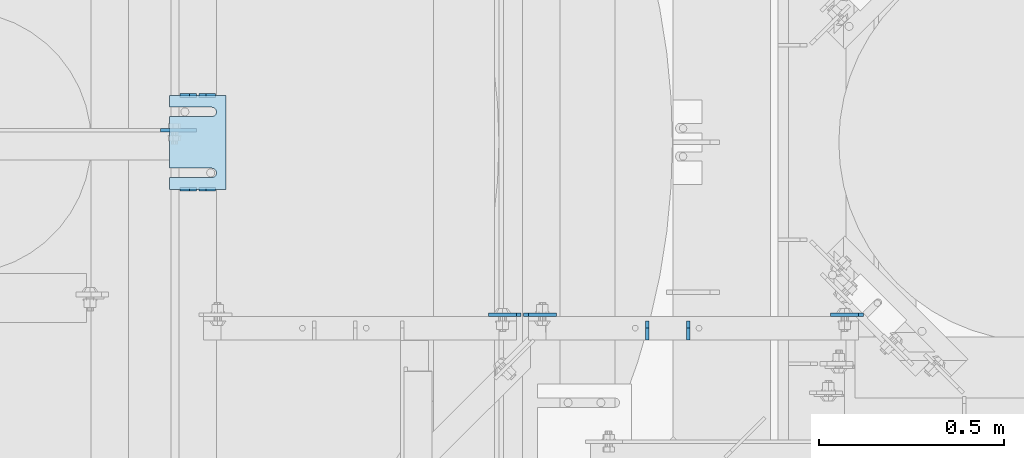
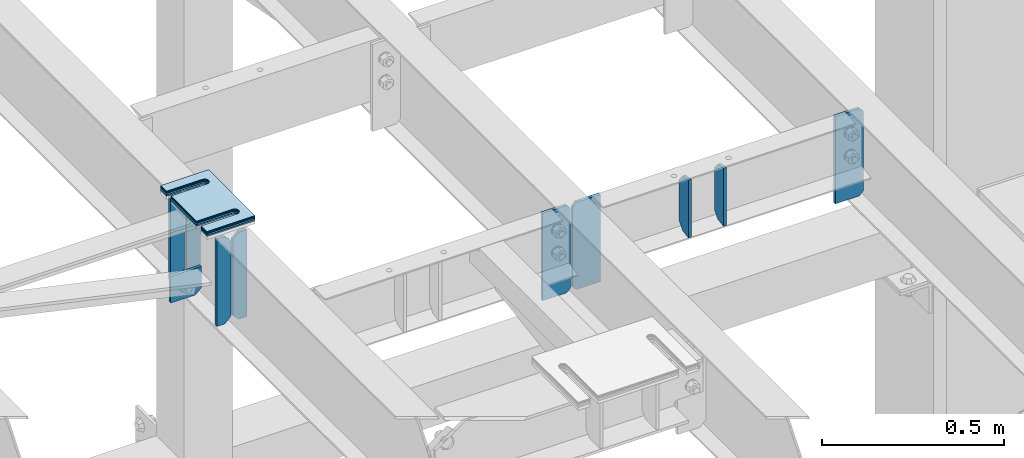
# One storey, part 1787 of 1876: 15 plates, 9 elements without a shape of their own.
"""IFC2X3 building model written with IfcOpenShell, lengths in millimetres."""

import ifcopenshell
import ifcopenshell.guid

model = None  # the IFC model being written
_history = None  # IfcOwnerHistory: only IFC2X3 demands one
_inside = {}  # id of a spatial element -> (the spatial element, [elements in it])
_under = {}  # id of a project, library or spatial element -> (it, [spatial elements below it])
_declared = {}  # id of a project -> (the project, [libraries it declares])
_typed = {}  # id of a type object -> (the type object, [elements of that type])
_made_of = {}  # id of a material, layer set ... -> (it, [elements and type objects made of it])


def new_model(schema):
    """Start an empty IFC model of exactly this schema.

    Asked for "IFC4X3", IfcOpenShell would pick the latest addendum, in which some entities
    have other attributes; the version numbers below select the first issue.
    IFC2X3 requires an IfcOwnerHistory on every rooted entity: one is made here for all.
    """
    global model, _history
    if schema == "IFC4X3":
        model = ifcopenshell.file(schema_version=(4, 3, 0, 0))
    else:
        model = ifcopenshell.file(schema=schema)
    _inside.clear()
    _under.clear()
    _declared.clear()
    _typed.clear()
    _made_of.clear()
    _history = None
    if model.schema == "IFC2X3":
        org = make("IfcOrganization", Name="unknown")
        user = make(
            "IfcPersonAndOrganization",
            ThePerson=make("IfcPerson", FamilyName="unknown"),
            TheOrganization=org,
        )
        app = make(
            "IfcApplication",
            ApplicationDeveloper=org,
            Version="unknown",
            ApplicationFullName="unknown",
            ApplicationIdentifier="unknown",
        )
        _history = make(
            "IfcOwnerHistory",
            OwningUser=user,
            OwningApplication=app,
            ChangeAction="ADDED",
            CreationDate=0,
        )
    return model


def make(cls, **values):
    """One entity of the class cls with the attributes given. An attribute that is None is left unset."""
    return model.create_entity(
        cls, **{name: value for name, value in values.items() if value is not None}
    )


def rooted(cls, **values):
    """An entity with a GlobalId (a new one), such as an element, a storey or a relation."""
    return make(cls, GlobalId=ifcopenshell.guid.new(), OwnerHistory=_history, **values)


def si_unit(unit_type, name, prefix=None):
    """IfcSIUnit, for example si_unit("LENGTHUNIT", "METRE", prefix="MILLI")."""
    return make("IfcSIUnit", UnitType=unit_type, Prefix=prefix, Name=name)


def assignment(units):
    """IfcUnitAssignment: the units of a project."""
    return None if units is None else make("IfcUnitAssignment", Units=units)


def point(xyz):
    """IfcCartesianPoint."""
    return None if xyz is None else make("IfcCartesianPoint", Coordinates=xyz)


def direction(xyz):
    """IfcDirection."""
    return None if xyz is None else make("IfcDirection", DirectionRatios=xyz)


def frame(location, z_axis=None, x_axis=None):
    """IfcAxis2Placement3D, a coordinate frame: its origin and axes. An axis left out is left unset."""
    return make(
        "IfcAxis2Placement3D",
        Location=point(location),
        Axis=direction(z_axis),
        RefDirection=direction(x_axis),
    )


def origin_with_axes():
    """The frame at (0, 0, 0) with the z axis (0, 0, 1) and the x axis (1, 0, 0) written out."""
    return frame((0.0, 0.0, 0.0), z_axis=(0.0, 0.0, 1.0), x_axis=(1.0, 0.0, 0.0))


def place(relative_to, where):
    """IfcLocalPlacement: puts the frame where relative to a parent placement (None: the world)."""
    return make(
        "IfcLocalPlacement", PlacementRelTo=relative_to, RelativePlacement=where
    )


def context(
    kind, dimensions, precision=None, world=None, true_north=None, identifier=None
):
    """IfcGeometricRepresentationContext, for example the 3D "Model" context."""
    return make(
        "IfcGeometricRepresentationContext",
        ContextIdentifier=identifier,
        ContextType=kind,
        CoordinateSpaceDimension=dimensions,
        Precision=precision,
        WorldCoordinateSystem=world,
        TrueNorth=true_north,
    )


def subcontext(parent, identifier, kind, view, scale=None):
    """IfcGeometricRepresentationSubContext, for example "Body" below "Model"."""
    return make(
        "IfcGeometricRepresentationSubContext",
        ContextIdentifier=identifier,
        ContextType=kind,
        ParentContext=parent,
        TargetScale=scale,
        TargetView=view,
    )


def project(units=None, contexts=None):
    """IfcProject with its units and contexts."""
    return rooted(
        "IfcProject",
        Name="project",
        RepresentationContexts=contexts,
        UnitsInContext=assignment(units),
    )


def spatial(cls, under=None, at=None, **own):
    """A site, building, storey or space (cls), placed at a placement, below another one or the project."""
    s = rooted(cls, ObjectPlacement=at, **own)
    if under is not None:
        _under.setdefault(under.id(), (under, []))[1].append(s)
    return s


def faces_of(points, faces, orient=None, outer=None):
    """IfcFace entities. A face is a list of loops; a loop is a list of indices into points, from 0.

    orient and outer hold one flag for each loop. By default every Orientation is true, the
    first loop of a face is its IfcFaceOuterBound and the others are IfcFaceBound.
    """
    made = []
    for i, loops in enumerate(faces):
        bounds = []
        for j, loop in enumerate(loops):
            is_outer = j == 0 if outer is None else outer[i][j]
            bounds.append(
                make(
                    "IfcFaceOuterBound" if is_outer else "IfcFaceBound",
                    Bound=make("IfcPolyLoop", Polygon=[points[k] for k in loop]),
                    Orientation=True if orient is None else orient[i][j],
                )
            )
        made.append(make("IfcFace", Bounds=bounds))
    return made


def faceted_brep(points, faces, orient=None, outer=None, voids=None):
    """IfcFacetedBrep: a solid bounded by flat faces; with voids (closed shells), ...WithVoids."""
    shared = [point(p) for p in points]
    hull = make("IfcClosedShell", CfsFaces=faces_of(shared, faces, orient, outer))
    if voids is None:
        return make("IfcFacetedBrep", Outer=hull)
    return make(
        "IfcFacetedBrepWithVoids",
        Outer=hull,
        Voids=[
            make(cls, CfsFaces=faces_of(shared, fs, o, b)) for cls, fs, o, b in voids
        ],
    )


def shape(context_of_items, identifier, shape_type, items):
    """IfcShapeRepresentation: the items that make up one representation, for example the "Body"."""
    return make(
        "IfcShapeRepresentation",
        ContextOfItems=context_of_items,
        RepresentationIdentifier=identifier,
        RepresentationType=shape_type,
        Items=items,
    )


def material(Name=None, Category=None):
    """IfcMaterial."""
    return make("IfcMaterial", Name=Name, Category=Category)


def made_of(thing, what):
    """Note that an element or type object is made of a material, layer set ...; save() writes the relation."""
    if what is not None:
        _made_of.setdefault(what.id(), (what, []))[1].append(thing)
    return thing


def type_object(cls, material=None, **own):
    """A type object (cls), such as IfcWallType, which elements share."""
    return made_of(rooted(cls, **own), material)


def element(
    cls,
    number,
    at=None,
    inside=None,
    cuts=None,
    type_object=None,
    material=None,
    context=None,
    identifier="Body",
    shape_type=None,
    held_by="IfcProductDefinitionShape",
    body=None,
    shapes=None,
    **own,
):
    """One element of the class cls, such as IfcWall. Its Tag is "e" and its number.

    at: its placement. inside: the storey or other place that contains it. cuts: it is an
    opening in that element (IfcRelVoidsElement). A single representation is given by context,
    identifier, shape_type and body (its items); several are given by shapes. held_by: the class
    of the entity that holds the representations. save() writes the other relations.
    """
    e = rooted(cls, Tag="e%d" % number, ObjectPlacement=at, **own)
    if body is not None:
        shapes = [shape(context, identifier, shape_type, body)]
    if shapes is not None:
        e.Representation = make(held_by, Representations=shapes)
    if inside is not None:
        _inside.setdefault(inside.id(), (inside, []))[1].append(e)
    if cuts is not None:
        rooted(
            "IfcRelVoidsElement", RelatingBuildingElement=cuts, RelatedOpeningElement=e
        )
    if type_object is not None:
        _typed.setdefault(type_object.id(), (type_object, []))[1].append(e)
    return made_of(e, material)


def aggregate(whole, parts):
    """IfcRelAggregates: a whole, such as a stair, and the parts it consists of."""
    return rooted("IfcRelAggregates", RelatingObject=whole, RelatedObjects=parts)


def save(model, path):
    """Write the relations noted so far, then the file.

    IfcRelAggregates (storeys below a building ...), IfcRelContainedInSpatialStructure (elements
    in a storey), IfcRelDefinesByType, IfcRelAssociatesMaterial and IfcRelDeclares: one each for
    every whole, place, type object, material and project.
    """
    for whole, parts in _under.values():
        aggregate(whole, parts)
    for where, things in _inside.values():
        rooted(
            "IfcRelContainedInSpatialStructure",
            RelatedElements=things,
            RelatingStructure=where,
        )
    for kind, things in _typed.values():
        rooted("IfcRelDefinesByType", RelatedObjects=things, RelatingType=kind)
    for what, things in _made_of.values():
        rooted("IfcRelAssociatesMaterial", RelatedObjects=things, RelatingMaterial=what)
    for by, libraries in _declared.values():
        rooted("IfcRelDeclares", RelatingContext=by, RelatedDefinitions=libraries)
    model.write(path)


model = new_model("IFC2X3")

# Units and contexts
model_context = context("Model", 3, precision=1e-05, world=origin_with_axes())
body_context = subcontext(model_context, "Body", "Model", "MODEL_VIEW")
ifc_project = project(units=[si_unit("LENGTHUNIT", "METRE", prefix="MILLI"), si_unit("AREAUNIT", "SQUARE_METRE"), si_unit("VOLUMEUNIT", "CUBIC_METRE"), si_unit("MASSUNIT", "GRAM", prefix="KILO"), si_unit("TIMEUNIT", "SECOND"), si_unit("PLANEANGLEUNIT", "RADIAN"), si_unit("SOLIDANGLEUNIT", "STERADIAN"), si_unit("THERMODYNAMICTEMPERATUREUNIT", "DEGREE_CELSIUS"), si_unit("LUMINOUSINTENSITYUNIT", "LUMEN")], contexts=[model_context])

# Site, building, storey
site_placement = place(None, origin_with_axes())
site = spatial("IfcSite", under=ifc_project, at=site_placement, CompositionType="ELEMENT")
building_placement = place(site_placement, origin_with_axes())
building = spatial("IfcBuilding", under=site, at=building_placement, Name="Undefined", CompositionType="ELEMENT")
storey_placement = place(building_placement, origin_with_axes())
storey = spatial("IfcBuildingStorey", under=building, at=storey_placement, Name="Undefined", CompositionType="ELEMENT", Elevation=0.0)

# Assembly, plates
assembly_1_placement = place(storey_placement, origin_with_axes())
assembly_1 = element("IfcElementAssembly", 1, at=assembly_1_placement, inside=storey, Name="BEAM", AssemblyPlace="NOTDEFINED", PredefinedType="RIGID_FRAME")
ifc_material = material(Name="STEEL/A36")
plate_type_1 = type_object("IfcPlateType", PredefinedType="NOTDEFINED")
plate_1_placement = place(assembly_1_placement, frame((3879.85, 11353.8028363018, 17684.75), z_axis=(0.0, 0.0, 1.0), x_axis=(-1.0, 0.0, 0.0)))
plate_1 = element("IfcPlate", 2, at=plate_1_placement, type_object=plate_type_1, material=ifc_material, Name="PLATE", context=body_context, shape_type="Brep", body=[
    faceted_brep([(0.0, -4.76249999999982, 0.0), (0.0, -4.76249999999982, 292.100006103516), (0.0, 4.76249999999982, 292.100006103516), (0.0, 4.76249999999982, 0.0), (25.4000015258789, -4.76250000000073, 292.100006103516), (25.4000015258789, 4.76250000000073, 292.100006103516), (44.4500007629395, -4.76250000000073, 273.050006866455), (44.4500007629395, 4.76250000000073, 273.050006866455), (44.4500007629395, -4.76250000000073, 19.0499992370605), (44.4500007629395, 4.76250000000073, 19.0499992370605), (25.4000015258789, -4.76250000000073, 0.0), (25.4000015258789, 4.76250000000073, 0.0)], [[[0, 1, 2, 3]], [[1, 4, 5, 2]], [[4, 6, 7, 5]], [[6, 8, 9, 7]], [[8, 10, 11, 9]], [[10, 0, 3, 11]], [[5, 7, 9, 11, 3, 2]], [[10, 8, 6, 4, 1, 0]]]),
])
plate_2_placement = place(assembly_1_placement, frame((3829.05, 11353.8028363018, 17684.75), z_axis=(0.0, 0.0, 1.0), x_axis=(-1.0, 0.0, 0.0)))
plate_2 = element("IfcPlate", 3, at=plate_2_placement, type_object=plate_type_1, material=ifc_material, Name="PLATE", context=body_context, shape_type="Brep", body=[
    faceted_brep([(0.0, -4.76249999999982, 19.0499992370605), (0.0, -4.76249999999982, 273.050006866455), (0.0, 4.76249999999982, 273.050006866455), (0.0, 4.76249999999982, 19.0499992370605), (19.0499992370605, -4.76249999999982, 292.100006103516), (19.0499992370605, 4.76249999999982, 292.100006103516), (44.4500007629395, -4.76250000000073, 292.100006103516), (44.4500007629395, 4.76250000000073, 292.100006103516), (44.4500007629395, -4.76249999999982, 0.0), (44.4500007629395, 4.76249999999982, 0.0), (19.0499992370605, -4.76249999999982, 0.0), (19.0499992370605, 4.76249999999982, 0.0)], [[[0, 1, 2, 3]], [[1, 4, 5, 2]], [[4, 6, 7, 5]], [[6, 8, 9, 7]], [[8, 10, 11, 9]], [[10, 0, 3, 11]], [[5, 7, 9, 11, 3, 2]], [[10, 8, 6, 4, 1, 0]]]),
])
plate_3_placement = place(assembly_1_placement, frame((3879.85, 11607.8023762535, 17684.75), z_axis=(0.0, 0.0, 1.0), x_axis=(-1.0, 0.0, 0.0)))
plate_3 = element("IfcPlate", 4, at=plate_3_placement, type_object=plate_type_1, material=ifc_material, Name="PLATE", context=body_context, shape_type="Brep", body=[
    faceted_brep([(0.0, -4.76249999999982, 0.0), (0.0, -4.76249999999982, 292.100006103516), (0.0, 4.76249999999982, 292.100006103516), (0.0, 4.76249999999982, 0.0), (25.4000015258789, -4.76250000000073, 292.100006103516), (25.4000015258789, 4.76250000000073, 292.100006103516), (44.4500007629395, -4.76250000000073, 273.050006866455), (44.4500007629395, 4.76250000000073, 273.050006866455), (44.4500007629395, -4.76250000000073, 19.0499992370605), (44.4500007629395, 4.76250000000073, 19.0499992370605), (25.4000015258789, -4.76250000000073, 0.0), (25.4000015258789, 4.76250000000073, 0.0)], [[[0, 1, 2, 3]], [[1, 4, 5, 2]], [[4, 6, 7, 5]], [[6, 8, 9, 7]], [[8, 10, 11, 9]], [[10, 0, 3, 11]], [[5, 7, 9, 11, 3, 2]], [[10, 8, 6, 4, 1, 0]]]),
])
plate_4_placement = place(assembly_1_placement, frame((3829.05, 11607.8023762535, 17684.75), z_axis=(0.0, 0.0, 1.0), x_axis=(-1.0, 0.0, 0.0)))
plate_4 = element("IfcPlate", 5, at=plate_4_placement, type_object=plate_type_1, material=ifc_material, Name="PLATE", context=body_context, shape_type="Brep", body=[
    faceted_brep([(0.0, -4.76249999999982, 19.0499992370605), (0.0, -4.76249999999982, 273.050006866455), (0.0, 4.76249999999982, 273.050006866455), (0.0, 4.76249999999982, 19.0499992370605), (19.0499992370605, -4.76249999999982, 292.100006103516), (19.0499992370605, 4.76249999999982, 292.100006103516), (44.4500007629395, -4.76250000000073, 292.100006103516), (44.4500007629395, 4.76250000000073, 292.100006103516), (44.4500007629395, -4.76249999999982, 0.0), (44.4500007629395, 4.76249999999982, 0.0), (19.0499992370605, -4.76249999999982, 0.0), (19.0499992370605, 4.76249999999982, 0.0)], [[[0, 1, 2, 3]], [[1, 4, 5, 2]], [[4, 6, 7, 5]], [[6, 8, 9, 7]], [[8, 10, 11, 9]], [[10, 0, 3, 11]], [[5, 7, 9, 11, 3, 2]], [[10, 8, 6, 4, 1, 0]]]),
])
plate_type_2 = type_object("IfcPlateType", PredefinedType="NOTDEFINED")
plate_5_placement = place(assembly_1_placement, frame((3731.43869979147, 11514.1401187102, 17773.7575293383), z_axis=(1.0, 0.0, 0.0), x_axis=(0.0, 0.0, -1.0)))
plate_5 = element("IfcPlate", 6, at=plate_5_placement, type_object=plate_type_2, material=ifc_material, Name="PLATE", context=body_context, shape_type="Brep", body=[
    faceted_brep([(0.0, -4.76249999999982, 0.0), (0.0, -4.76249999991705, 97.6116790771484), (0.0, 4.76250000008258, 97.6116790771498), (0.0, 4.76249999999982, 0.0), (69.9575309753418, -4.76249999991705, 97.6116790771484), (69.9575309753418, 4.76250000008258, 97.6116790771498), (89.0075302124023, -4.76249999993524, 78.5616798400883), (89.0075302124023, 4.76250000006621, 78.5616798400893), (89.0075302124023, -4.76249999999891, 1.81898940354586e-12), (89.0075302124023, 4.76250000000255, 3.18323145620525e-12)], [[[0, 1, 2, 3]], [[1, 4, 5, 2]], [[4, 6, 7, 5]], [[6, 8, 9, 7]], [[8, 0, 3, 9]], [[5, 7, 9, 3, 2]], [[8, 6, 4, 1, 0]]]),
])
aggregate(assembly_1, [plate_1, plate_2, plate_3, plate_4, plate_5])

# Assembly, plate
assembly_2_placement = place(storey_placement, origin_with_axes())
assembly_2 = element("IfcElementAssembly", 7, at=assembly_2_placement, inside=storey, Name="BEAM", AssemblyPlace="NOTDEFINED", PredefinedType="RIGID_FRAME")
plate_6_placement = place(assembly_2_placement, frame((5635.625, 11014.0759998322, 17684.75), z_axis=(0.0, 0.0, 1.0), x_axis=(-1.0, 0.0, 0.0)))
plate_6 = element("IfcPlate", 8, at=plate_6_placement, type_object=plate_type_2, material=ifc_material, Name="PLATE", context=body_context, shape_type="Brep", body=[
    faceted_brep([(3.7040990719106e-08, -4.76249999999982, 12.6999998092651), (0.0, -4.76249999999982, 279.40000629425), (0.0, 4.76249999999982, 279.40000629425), (3.70396264770534e-08, 4.76249999999982, 12.6999998092651), (12.6999998092651, -4.76249999999982, 292.100006103516), (12.6999998092651, 4.76249999999982, 292.100006103516), (88.9000015258789, -4.76249999999982, 292.100006103516), (88.9000015258789, 4.76249999999982, 292.100006103516), (88.9000015258789, -4.76249999999982, 0.0), (88.9000015258789, 4.76249999999982, 0.0), (12.699999809267, -4.76249999999754, 1.09139364212751e-11), (12.6999998092651, 4.76250000000255, 1.09139364212751e-11)], [[[0, 1, 2, 3]], [[1, 4, 5, 2]], [[4, 6, 7, 5]], [[6, 8, 9, 7]], [[8, 10, 11, 9]], [[10, 0, 3, 11]], [[5, 7, 9, 11, 3, 2]], [[10, 8, 6, 4, 1, 0]]]),
])
aggregate(assembly_2, [plate_6])

# Assembly, plates
assembly_3_placement = place(storey_placement, origin_with_axes())
assembly_3 = element("IfcElementAssembly", 9, at=assembly_3_placement, inside=storey, Name="BEAM", AssemblyPlace="NOTDEFINED", PredefinedType="RIGID_FRAME")
plate_7_placement = place(assembly_3_placement, frame((4714.875, 11014.0759998322, 17684.75), z_axis=(0.0, 0.0, 1.0), x_axis=(1.0, 0.0, 0.0)))
plate_7 = element("IfcPlate", 10, at=plate_7_placement, type_object=plate_type_2, material=ifc_material, Name="PLATE", context=body_context, shape_type="Brep", body=[
    faceted_brep([(3.7040990719106e-08, -4.76249999999982, 12.6999998092651), (0.0, -4.76249999999982, 279.40000629425), (0.0, 4.76249999999982, 279.40000629425), (3.70396264770534e-08, 4.76249999999982, 12.6999998092651), (12.6999998092651, -4.76249999999982, 292.100006103516), (12.6999998092651, 4.76249999999982, 292.100006103516), (88.9000015258789, -4.76249999999982, 292.100006103516), (88.9000015258789, 4.76249999999982, 292.100006103516), (88.9000015258789, -4.76249999999982, 0.0), (88.9000015258789, 4.76249999999982, 0.0), (12.699999809267, -4.76249999999754, 1.09139364212751e-11), (12.6999998092651, 4.76250000000255, 1.09139364212751e-11)], [[[0, 1, 2, 3]], [[1, 4, 5, 2]], [[4, 6, 7, 5]], [[6, 8, 9, 7]], [[8, 10, 11, 9]], [[10, 0, 3, 11]], [[5, 7, 9, 11, 3, 2]], [[10, 8, 6, 4, 1, 0]]]),
])
plate_8_placement = place(assembly_3_placement, frame((4708.525, 11014.0754999161, 17684.75), z_axis=(0.0, 0.0, 1.0), x_axis=(-1.0, 0.0, 0.0)))
plate_8 = element("IfcPlate", 11, at=plate_8_placement, type_object=plate_type_2, material=ifc_material, Name="PLATE", context=body_context, shape_type="Brep", body=[
    faceted_brep([(3.7040990719106e-08, -4.76249999999982, 12.6999998092651), (0.0, -4.76249999999982, 279.40000629425), (0.0, 4.76249999999982, 279.40000629425), (3.70396264770534e-08, 4.76249999999982, 12.6999998092651), (12.6999998092651, -4.76249999999982, 292.100006103516), (12.6999998092651, 4.76249999999982, 292.100006103516), (88.9000015258789, -4.76249999999982, 292.100006103516), (88.9000015258789, 4.76249999999982, 292.100006103516), (88.9000015258789, -4.76249999999982, 0.0), (88.9000015258789, 4.76249999999982, 0.0), (12.699999809267, -4.76249999999754, 1.09139364212751e-11), (12.6999998092651, 4.76250000000255, 1.09139364212751e-11)], [[[0, 1, 2, 3]], [[1, 4, 5, 2]], [[4, 6, 7, 5]], [[6, 8, 9, 7]], [[8, 10, 11, 9]], [[10, 0, 3, 11]], [[5, 7, 9, 11, 3, 2]], [[10, 8, 6, 4, 1, 0]]]),
])
aggregate(assembly_3, [plate_7, plate_8])

# Assembly, plate
assembly_4_placement = place(storey_placement, origin_with_axes())
assembly_4 = element("IfcElementAssembly", 12, at=assembly_4_placement, inside=storey, Name="SHIM PLATE", AssemblyPlace="NOTDEFINED", PredefinedType="RIGID_FRAME")
plate_type_3 = type_object("IfcPlateType", PredefinedType="NOTDEFINED")
plate_9_placement = place(assembly_4_placement, frame((3908.44515556677, 11353.8028259284, 18009.3925), z_axis=(-1.0, 0.0, 0.0), x_axis=(0.0, 1.0, 0.0)))
plate_9 = element("IfcPlate", 13, at=plate_9_placement, type_object=plate_type_3, material=ifc_material, Name="SHIM PLATE", context=body_context, shape_type="Brep", body=[
    faceted_brep([(31.7473236467022, -0.793499999999767, 152.398895263674), (31.7495452849444, -0.793499999999767, 38.0994505459066), (31.7495452849444, 0.793499999999767, 38.0994505459066), (31.7473236467022, 0.793499999999767, 152.398895263674), (33.4510181364694, -0.793499999999767, 31.7494480392982), (33.4510181364694, 0.793499999999767, 31.7494480392982), (38.0995388011806, -0.793499999999767, 27.1009216783834), (38.0995388011806, 0.793499999999767, 27.1009216783834), (44.4495392228328, -0.793499999999767, 25.3994410457015), (44.4495392228328, 0.793499999999767, 25.3994410457015), (50.7995409628356, -0.793499999999767, 27.1009167582527), (50.7995409628356, 0.793499999999767, 27.1009167582527), (55.4480652293469, -0.793499999999767, 31.7494395173824), (55.4480652293469, 0.793499999999767, 31.7494395173824), (57.14954300102, -0.793499999999767, 38.0994407056476), (57.14954300102, 0.793499999999767, 38.0994407056476), (57.1473213626687, -0.793499999999767, 152.398894419415), (57.1473213626687, 0.793499999999767, 152.398895263676), (9.09494701772928e-13, -0.793499999999767, 0.0), (1.98268335225293e-05, -0.793499999999767, 152.398895263672), (1.98268335225293e-05, 0.793499999999767, 152.398895263672), (9.09494701772928e-13, 0.793499999999767, 0.0), (253.999542236328, -0.793499999999767, 6.16182660451159e-11), (253.999542236328, 0.793499999999767, 6.16182660451159e-11), (253.999557495107, -0.793499999999767, 152.398895263688), (253.999557495107, 0.793499999999767, 152.398895263688), (222.247321362667, 0.793499999999767, 152.398895263686), (222.247321362667, -0.793499999999767, 152.398895410166), (222.249543001019, 0.793499999999767, 38.0994416963979), (222.249543001019, -0.793499999999767, 38.0994416963979), (220.548065229345, 0.793499999999767, 31.7494405081325), (220.548065229345, -0.793499999999767, 31.7494405081325), (215.899540962834, 0.793499999999767, 27.100917749003), (215.899540962834, -0.793499999999767, 27.100917749003), (209.549539222831, 0.793499999999767, 25.3994420364518), (209.549539222831, -0.793499999999767, 25.3994420364518), (203.199538801179, 0.793499999999767, 27.1009226691335), (203.199538801179, -0.793499999999767, 27.1009226691335), (198.551018136468, 0.793499999999767, 31.7494490300483), (198.551018136468, -0.793499999999767, 31.7494490300483), (196.849545284943, 0.793499999999767, 38.0994515366567), (196.849545284943, -0.793499999999767, 38.0994515366567), (196.847323646701, -0.793499999999767, 152.398895263684), (196.847323646701, 0.793499999999767, 152.398895263684)], [[[0, 1, 2, 3]], [[4, 5, 2, 1]], [[6, 7, 5, 4]], [[8, 9, 7, 6]], [[10, 11, 9, 8]], [[12, 13, 11, 10]], [[14, 15, 13, 12]], [[16, 17, 15, 14]], [[18, 19, 20, 21]], [[22, 18, 21, 23]], [[24, 22, 23, 25]], [[24, 25, 26, 27]], [[27, 26, 28, 29]], [[29, 28, 30, 31]], [[31, 30, 32, 33]], [[33, 32, 34, 35]], [[35, 34, 36, 37]], [[37, 36, 38, 39]], [[39, 38, 40, 41]], [[42, 41, 40, 43]], [[12, 10, 8, 6, 4, 1, 0, 19, 18, 22, 24, 27, 29, 31, 33, 35, 37, 39, 41, 42, 16, 14]], [[20, 19, 0, 3]], [[43, 40, 38, 36, 34, 32, 30, 28, 26, 25, 23, 21, 20, 3, 2, 5, 7, 9, 11, 13, 15, 17]], [[42, 43, 17, 16]]]),
])
aggregate(assembly_4, [plate_9])

assembly_5_placement = place(storey_placement, origin_with_axes())
assembly_5 = element("IfcElementAssembly", 14, at=assembly_5_placement, inside=storey, Name="SHIM PLATE", AssemblyPlace="NOTDEFINED", PredefinedType="RIGID_FRAME")
plate_type_4 = type_object("IfcPlateType", PredefinedType="NOTDEFINED")
plate_10_placement = place(assembly_5_placement, frame((3908.4451555663, 11353.8028259282, 18007.0115), z_axis=(-1.0, 0.0, 0.0), x_axis=(0.0, 1.0, 0.0)))
plate_10 = element("IfcPlate", 15, at=plate_10_placement, type_object=plate_type_4, material=ifc_material, Name="SHIM PLATE", context=body_context, shape_type="Brep", body=[
    faceted_brep([(31.7473236467022, -1.58750000000146, 152.398895263674), (31.7495452849444, -1.58750000000146, 38.0994505459066), (31.7495452849444, 1.58750000000146, 38.0994505459066), (31.7473236467022, 1.58750000000146, 152.398895263674), (33.4510181364694, -1.58750000000146, 31.7494480392982), (33.4510181364694, 1.58750000000146, 31.7494480392982), (38.0995388011806, -1.58750000000146, 27.1009216783834), (38.0995388011806, 1.58750000000146, 27.1009216783834), (44.4495392228328, -1.58750000000146, 25.3994410457015), (44.4495392228328, 1.58750000000146, 25.3994410457015), (50.7995409628356, -1.58750000000146, 27.1009167582527), (50.7995409628356, 1.58750000000146, 27.1009167582527), (55.4480652293469, -1.58750000000146, 31.7494395173824), (55.4480652293469, 1.58750000000146, 31.7494395173824), (57.14954300102, -1.58750000000146, 38.0994407056476), (57.14954300102, 1.58750000000146, 38.0994407056476), (57.1473213626687, -1.58750000000146, 152.398894419415), (57.1473213626687, 1.58750000000146, 152.398895263676), (9.09494701772928e-13, -1.58750000000146, 4.54747350886464e-13), (1.98264133359771e-05, -1.58750000000146, 152.398895263672), (1.98264133359771e-05, 1.58750000000146, 152.398895263672), (9.09494701772928e-13, 1.58750000000146, 4.54747350886464e-13), (253.999542236328, -1.58750000000146, 6.16182660451159e-11), (253.999542236328, 1.58750000000146, 6.16182660451159e-11), (253.999557495107, -1.58750000000146, 152.398895263688), (253.999557495107, 1.58750000000146, 152.398895263688), (222.247321362667, 1.58750000000146, 152.398895263686), (222.247321362667, -1.58750000000146, 152.398895410166), (222.249543001019, 1.58750000000146, 38.0994416963979), (222.249543001019, -1.58750000000146, 38.0994416963979), (220.548065229345, 1.58750000000146, 31.7494405081325), (220.548065229345, -1.58750000000146, 31.7494405081325), (215.899540962834, 1.58750000000146, 27.100917749003), (215.899540962834, -1.58750000000146, 27.100917749003), (209.549539222831, 1.58750000000146, 25.3994420364518), (209.549539222831, -1.58750000000146, 25.3994420364518), (203.199538801179, 1.58750000000146, 27.1009226691335), (203.199538801179, -1.58750000000146, 27.1009226691335), (198.551018136468, 1.58750000000146, 31.7494490300483), (198.551018136468, -1.58750000000146, 31.7494490300483), (196.849545284943, 1.58750000000146, 38.0994515366567), (196.849545284943, -1.58750000000146, 38.0994515366567), (196.847323646701, -1.58750000000146, 152.398895263684), (196.847323646701, 1.58750000000146, 152.398895263684)], [[[0, 1, 2, 3]], [[4, 5, 2, 1]], [[6, 7, 5, 4]], [[8, 9, 7, 6]], [[10, 11, 9, 8]], [[12, 13, 11, 10]], [[14, 15, 13, 12]], [[16, 17, 15, 14]], [[18, 19, 20, 21]], [[22, 18, 21, 23]], [[24, 22, 23, 25]], [[24, 25, 26, 27]], [[27, 26, 28, 29]], [[29, 28, 30, 31]], [[31, 30, 32, 33]], [[33, 32, 34, 35]], [[35, 34, 36, 37]], [[37, 36, 38, 39]], [[39, 38, 40, 41]], [[42, 41, 40, 43]], [[12, 10, 8, 6, 4, 1, 0, 19, 18, 22, 24, 27, 29, 31, 33, 35, 37, 39, 41, 42, 16, 14]], [[20, 19, 0, 3]], [[43, 40, 38, 36, 34, 32, 30, 28, 26, 25, 23, 21, 20, 3, 2, 5, 7, 9, 11, 13, 15, 17]], [[42, 43, 17, 16]]]),
])
aggregate(assembly_5, [plate_10])

assembly_6_placement = place(storey_placement, origin_with_axes())
assembly_6 = element("IfcElementAssembly", 16, at=assembly_6_placement, inside=storey, Name="SHIM PLATE", AssemblyPlace="NOTDEFINED", PredefinedType="RIGID_FRAME")
plate_11_placement = place(assembly_6_placement, frame((3908.44515556584, 11353.8028259281, 18003.8365), z_axis=(-1.0, 0.0, 0.0), x_axis=(0.0, 1.0, 0.0)))
plate_11 = element("IfcPlate", 17, at=plate_11_placement, type_object=plate_type_4, material=ifc_material, Name="SHIM PLATE", context=body_context, shape_type="Brep", body=[
    faceted_brep([(31.7473236467022, -1.58750000000146, 152.398895263674), (31.7495452849444, -1.58750000000146, 38.0994505459066), (31.7495452849444, 1.58750000000146, 38.0994505459066), (31.7473236467022, 1.58750000000146, 152.398895263674), (33.4510181364694, -1.58750000000146, 31.7494480392982), (33.4510181364694, 1.58750000000146, 31.7494480392982), (38.0995388011806, -1.58750000000146, 27.1009216783834), (38.0995388011806, 1.58750000000146, 27.1009216783834), (44.4495392228328, -1.58750000000146, 25.3994410457015), (44.4495392228328, 1.58750000000146, 25.3994410457015), (50.7995409628356, -1.58750000000146, 27.1009167582527), (50.7995409628356, 1.58750000000146, 27.1009167582527), (55.4480652293469, -1.58750000000146, 31.7494395173824), (55.4480652293469, 1.58750000000146, 31.7494395173824), (57.14954300102, -1.58750000000146, 38.0994407056476), (57.14954300102, 1.58750000000146, 38.0994407056476), (57.1473213626687, -1.58750000000146, 152.398894419415), (57.1473213626687, 1.58750000000146, 152.398895263676), (9.09494701772928e-13, -1.58750000000146, 4.54747350886464e-13), (1.98264133359771e-05, -1.58750000000146, 152.398895263672), (1.98264133359771e-05, 1.58750000000146, 152.398895263672), (9.09494701772928e-13, 1.58750000000146, 4.54747350886464e-13), (253.999542236328, -1.58750000000146, 6.16182660451159e-11), (253.999542236328, 1.58750000000146, 6.16182660451159e-11), (253.999557495107, -1.58750000000146, 152.398895263688), (253.999557495107, 1.58750000000146, 152.398895263688), (222.247321362667, 1.58750000000146, 152.398895263686), (222.247321362667, -1.58750000000146, 152.398895410166), (222.249543001019, 1.58750000000146, 38.0994416963979), (222.249543001019, -1.58750000000146, 38.0994416963979), (220.548065229345, 1.58750000000146, 31.7494405081325), (220.548065229345, -1.58750000000146, 31.7494405081325), (215.899540962834, 1.58750000000146, 27.100917749003), (215.899540962834, -1.58750000000146, 27.100917749003), (209.549539222831, 1.58750000000146, 25.3994420364518), (209.549539222831, -1.58750000000146, 25.3994420364518), (203.199538801179, 1.58750000000146, 27.1009226691335), (203.199538801179, -1.58750000000146, 27.1009226691335), (198.551018136468, 1.58750000000146, 31.7494490300483), (198.551018136468, -1.58750000000146, 31.7494490300483), (196.849545284943, 1.58750000000146, 38.0994515366567), (196.849545284943, -1.58750000000146, 38.0994515366567), (196.847323646701, -1.58750000000146, 152.398895263684), (196.847323646701, 1.58750000000146, 152.398895263684)], [[[0, 1, 2, 3]], [[4, 5, 2, 1]], [[6, 7, 5, 4]], [[8, 9, 7, 6]], [[10, 11, 9, 8]], [[12, 13, 11, 10]], [[14, 15, 13, 12]], [[16, 17, 15, 14]], [[18, 19, 20, 21]], [[22, 18, 21, 23]], [[24, 22, 23, 25]], [[24, 25, 26, 27]], [[27, 26, 28, 29]], [[29, 28, 30, 31]], [[31, 30, 32, 33]], [[33, 32, 34, 35]], [[35, 34, 36, 37]], [[37, 36, 38, 39]], [[39, 38, 40, 41]], [[42, 41, 40, 43]], [[12, 10, 8, 6, 4, 1, 0, 19, 18, 22, 24, 27, 29, 31, 33, 35, 37, 39, 41, 42, 16, 14]], [[20, 19, 0, 3]], [[43, 40, 38, 36, 34, 32, 30, 28, 26, 25, 23, 21, 20, 3, 2, 5, 7, 9, 11, 13, 15, 17]], [[42, 43, 17, 16]]]),
])
aggregate(assembly_6, [plate_11])

assembly_7_placement = place(storey_placement, origin_with_axes())
assembly_7 = element("IfcElementAssembly", 18, at=assembly_7_placement, inside=storey, Name="SHIM PLATE", AssemblyPlace="NOTDEFINED", PredefinedType="RIGID_FRAME")
plate_type_5 = type_object("IfcPlateType", PredefinedType="NOTDEFINED")
plate_12_placement = place(assembly_7_placement, frame((3908.44515556538, 11353.802825928, 17999.868), z_axis=(-1.0, 0.0, 0.0), x_axis=(0.0, 1.0, 0.0)))
plate_12 = element("IfcPlate", 19, at=plate_12_placement, type_object=plate_type_5, material=ifc_material, Name="SHIM PLATE", context=body_context, shape_type="Brep", body=[
    faceted_brep([(31.7473236467022, -2.38100000000122, 152.398895263674), (31.7495452849444, -2.38100000000122, 38.0994505459066), (31.7495452849444, 2.38100000000122, 38.0994505459066), (31.7473236467022, 2.38100000000122, 152.398895263674), (33.4510181364694, -2.38100000000122, 31.7494480392982), (33.4510181364694, 2.38100000000122, 31.7494480392982), (38.0995388011806, -2.38100000000122, 27.1009216783834), (38.0995388011806, 2.38100000000122, 27.1009216783834), (44.4495392228328, -2.38100000000122, 25.3994410457015), (44.4495392228328, 2.38100000000122, 25.3994410457015), (50.7995409628356, -2.38100000000122, 27.1009167582527), (50.7995409628356, 2.38100000000122, 27.1009167582527), (55.4480652293469, -2.38100000000122, 31.7494395173824), (55.4480652293469, 2.38100000000122, 31.7494395173824), (57.14954300102, -2.38100000000122, 38.0994407056476), (57.14954300102, 2.38100000000122, 38.0994407056476), (57.1473213626687, -2.38100000000122, 152.398894419415), (57.1473213626687, 2.38100000000122, 152.398895263676), (0.0, -2.38100000000122, 4.54747350886464e-13), (1.98259931494249e-05, -2.38100000000122, 152.398895263672), (1.98259931494249e-05, 2.38100000000122, 152.398895263672), (0.0, 2.38100000000122, 4.54747350886464e-13), (253.999542236328, -2.38100000000122, 6.16182660451159e-11), (253.999542236328, 2.38100000000122, 6.16182660451159e-11), (253.999557495107, -2.38100000000122, 152.398895263688), (253.999557495107, 2.38100000000122, 152.398895263688), (222.247321362667, 2.38100000000122, 152.398895263686), (222.247321362667, -2.38100000000122, 152.398895410166), (222.249543001019, 2.38100000000122, 38.0994416963979), (222.249543001019, -2.38100000000122, 38.0994416963979), (220.548065229345, 2.38100000000122, 31.7494405081325), (220.548065229345, -2.38100000000122, 31.7494405081325), (215.899540962834, 2.38100000000122, 27.100917749003), (215.899540962834, -2.38100000000122, 27.100917749003), (209.549539222831, 2.38100000000122, 25.3994420364518), (209.549539222831, -2.38100000000122, 25.3994420364518), (203.199538801179, 2.38100000000122, 27.1009226691335), (203.199538801179, -2.38100000000122, 27.1009226691335), (198.551018136468, 2.38100000000122, 31.7494490300483), (198.551018136468, -2.38100000000122, 31.7494490300483), (196.849545284943, 2.38100000000122, 38.0994515366567), (196.849545284943, -2.38100000000122, 38.0994515366567), (196.847323646701, -2.38100000000122, 152.398895263684), (196.847323646701, 2.38100000000122, 152.398895263684)], [[[0, 1, 2, 3]], [[4, 5, 2, 1]], [[6, 7, 5, 4]], [[8, 9, 7, 6]], [[10, 11, 9, 8]], [[12, 13, 11, 10]], [[14, 15, 13, 12]], [[16, 17, 15, 14]], [[18, 19, 20, 21]], [[22, 18, 21, 23]], [[24, 22, 23, 25]], [[24, 25, 26, 27]], [[27, 26, 28, 29]], [[29, 28, 30, 31]], [[31, 30, 32, 33]], [[33, 32, 34, 35]], [[35, 34, 36, 37]], [[37, 36, 38, 39]], [[39, 38, 40, 41]], [[42, 41, 40, 43]], [[12, 10, 8, 6, 4, 1, 0, 19, 18, 22, 24, 27, 29, 31, 33, 35, 37, 39, 41, 42, 16, 14]], [[20, 19, 0, 3]], [[43, 40, 38, 36, 34, 32, 30, 28, 26, 25, 23, 21, 20, 3, 2, 5, 7, 9, 11, 13, 15, 17]], [[42, 43, 17, 16]]]),
])
aggregate(assembly_7, [plate_12])

assembly_8_placement = place(storey_placement, origin_with_axes())
assembly_8 = element("IfcElementAssembly", 20, at=assembly_8_placement, inside=storey, Name="SHIM PLATE", AssemblyPlace="NOTDEFINED", PredefinedType="RIGID_FRAME")
plate_13_placement = place(assembly_8_placement, frame((3908.44515556492, 11353.8028259278, 17995.106), z_axis=(-1.0, 0.0, 0.0), x_axis=(0.0, 1.0, 0.0)))
plate_13 = element("IfcPlate", 21, at=plate_13_placement, type_object=plate_type_5, material=ifc_material, Name="SHIM PLATE", context=body_context, shape_type="Brep", body=[
    faceted_brep([(31.7473236467022, -2.38100000000122, 152.398895263674), (31.7495452849444, -2.38100000000122, 38.0994505459066), (31.7495452849444, 2.38100000000122, 38.0994505459066), (31.7473236467022, 2.38100000000122, 152.398895263674), (33.4510181364694, -2.38100000000122, 31.7494480392982), (33.4510181364694, 2.38100000000122, 31.7494480392982), (38.0995388011806, -2.38100000000122, 27.1009216783834), (38.0995388011806, 2.38100000000122, 27.1009216783834), (44.4495392228328, -2.38100000000122, 25.3994410457015), (44.4495392228328, 2.38100000000122, 25.3994410457015), (50.7995409628356, -2.38100000000122, 27.1009167582527), (50.7995409628356, 2.38100000000122, 27.1009167582527), (55.4480652293469, -2.38100000000122, 31.7494395173824), (55.4480652293469, 2.38100000000122, 31.7494395173824), (57.14954300102, -2.38100000000122, 38.0994407056476), (57.14954300102, 2.38100000000122, 38.0994407056476), (57.1473213626687, -2.38100000000122, 152.398894419415), (57.1473213626687, 2.38100000000122, 152.398895263676), (0.0, -2.38100000000122, 4.54747350886464e-13), (1.98259931494249e-05, -2.38100000000122, 152.398895263672), (1.98259931494249e-05, 2.38100000000122, 152.398895263672), (0.0, 2.38100000000122, 4.54747350886464e-13), (253.999542236328, -2.38100000000122, 6.16182660451159e-11), (253.999542236328, 2.38100000000122, 6.16182660451159e-11), (253.999557495107, -2.38100000000122, 152.398895263688), (253.999557495107, 2.38100000000122, 152.398895263688), (222.247321362667, 2.38100000000122, 152.398895263686), (222.247321362667, -2.38100000000122, 152.398895410166), (222.249543001019, 2.38100000000122, 38.0994416963979), (222.249543001019, -2.38100000000122, 38.0994416963979), (220.548065229345, 2.38100000000122, 31.7494405081325), (220.548065229345, -2.38100000000122, 31.7494405081325), (215.899540962834, 2.38100000000122, 27.100917749003), (215.899540962834, -2.38100000000122, 27.100917749003), (209.549539222831, 2.38100000000122, 25.3994420364518), (209.549539222831, -2.38100000000122, 25.3994420364518), (203.199538801179, 2.38100000000122, 27.1009226691335), (203.199538801179, -2.38100000000122, 27.1009226691335), (198.551018136468, 2.38100000000122, 31.7494490300483), (198.551018136468, -2.38100000000122, 31.7494490300483), (196.849545284943, 2.38100000000122, 38.0994515366567), (196.849545284943, -2.38100000000122, 38.0994515366567), (196.847323646701, -2.38100000000122, 152.398895263684), (196.847323646701, 2.38100000000122, 152.398895263684)], [[[0, 1, 2, 3]], [[4, 5, 2, 1]], [[6, 7, 5, 4]], [[8, 9, 7, 6]], [[10, 11, 9, 8]], [[12, 13, 11, 10]], [[14, 15, 13, 12]], [[16, 17, 15, 14]], [[18, 19, 20, 21]], [[22, 18, 21, 23]], [[24, 22, 23, 25]], [[24, 25, 26, 27]], [[27, 26, 28, 29]], [[29, 28, 30, 31]], [[31, 30, 32, 33]], [[33, 32, 34, 35]], [[35, 34, 36, 37]], [[37, 36, 38, 39]], [[39, 38, 40, 41]], [[42, 41, 40, 43]], [[12, 10, 8, 6, 4, 1, 0, 19, 18, 22, 24, 27, 29, 31, 33, 35, 37, 39, 41, 42, 16, 14]], [[20, 19, 0, 3]], [[43, 40, 38, 36, 34, 32, 30, 28, 26, 25, 23, 21, 20, 3, 2, 5, 7, 9, 11, 13, 15, 17]], [[42, 43, 17, 16]]]),
])
aggregate(assembly_8, [plate_13])

# Assembly, plates
assembly_9_placement = place(storey_placement, origin_with_axes())
assembly_9 = element("IfcElementAssembly", 22, at=assembly_9_placement, inside=storey, Name="BEAM", AssemblyPlace="NOTDEFINED", PredefinedType="RIGID_FRAME")
plate_type_6 = type_object("IfcPlateType", PredefinedType="NOTDEFINED")
plate_14_placement = place(assembly_9_placement, frame((5049.83743973152, 10945.8129999161, 17784.23545), z_axis=(0.0, -0.164335003932506, 0.986404585594827), x_axis=(0.0, 0.986404585594827, 0.164335003932506)))
plate_14 = element("IfcPlate", 23, at=plate_14_placement, type_object=plate_type_6, material=ifc_material, Name="PLATE", context=body_context, shape_type="Brep", body=[
    faceted_brep([(0.0, -4.76249999999982, 0.0), (32.0008087158794, -4.76249999999982, 192.081680297815), (32.0008087158794, 4.76249999999982, 192.081680297815), (0.0, 4.76249999999982, 0.0), (62.6982748962027, -4.76249999999982, 181.561281061485), (62.6982748962027, 4.76249999999982, 181.561281061485), (77.5887637589458, -4.76249999999982, 156.594231983478), (77.5887637589458, 4.76249999999982, 156.594231983478), (54.6307491805464, -4.76249999999982, 18.791006663906), (54.6307491805464, 4.76249999999982, 18.791006663906), (32.4501686096137, -4.76249999999982, -1.63709046319127e-11), (32.4501686096137, 4.76249999999982, -1.63709046319127e-11)], [[[0, 1, 2, 3]], [[1, 4, 5, 2]], [[4, 6, 7, 5]], [[6, 8, 9, 7]], [[8, 10, 11, 9]], [[10, 0, 3, 11]], [[5, 7, 9, 11, 3, 2]], [[10, 8, 6, 4, 1, 0]]]),
])
plate_15_placement = place(assembly_9_placement, frame((5160.96243973152, 10945.8129999161, 17784.23545), z_axis=(0.0, -0.164335003932506, 0.986404585594827), x_axis=(0.0, 0.986404585594827, 0.164335003932506)))
plate_15 = element("IfcPlate", 24, at=plate_15_placement, type_object=plate_type_6, material=ifc_material, Name="PLATE", context=body_context, shape_type="Brep", body=[
    faceted_brep([(0.0, -4.76249999999982, 0.0), (32.0008087158794, -4.76249999999982, 192.081680297815), (32.0008087158794, 4.76249999999982, 192.081680297815), (0.0, 4.76249999999982, 0.0), (62.6982748962027, -4.76249999999982, 181.561281061485), (62.6982748962027, 4.76249999999982, 181.561281061485), (77.5887637589458, -4.76249999999982, 156.594231983478), (77.5887637589458, 4.76249999999982, 156.594231983478), (54.6307491805464, -4.76249999999982, 18.791006663906), (54.6307491805464, 4.76249999999982, 18.791006663906), (32.4501686096137, -4.76249999999982, -1.63709046319127e-11), (32.4501686096137, 4.76249999999982, -1.63709046319127e-11)], [[[0, 1, 2, 3]], [[1, 4, 5, 2]], [[4, 6, 7, 5]], [[6, 8, 9, 7]], [[8, 10, 11, 9]], [[10, 0, 3, 11]], [[5, 7, 9, 11, 3, 2]], [[10, 8, 6, 4, 1, 0]]]),
])
aggregate(assembly_9, [plate_14, plate_15])

save(model, "model.ifc")
